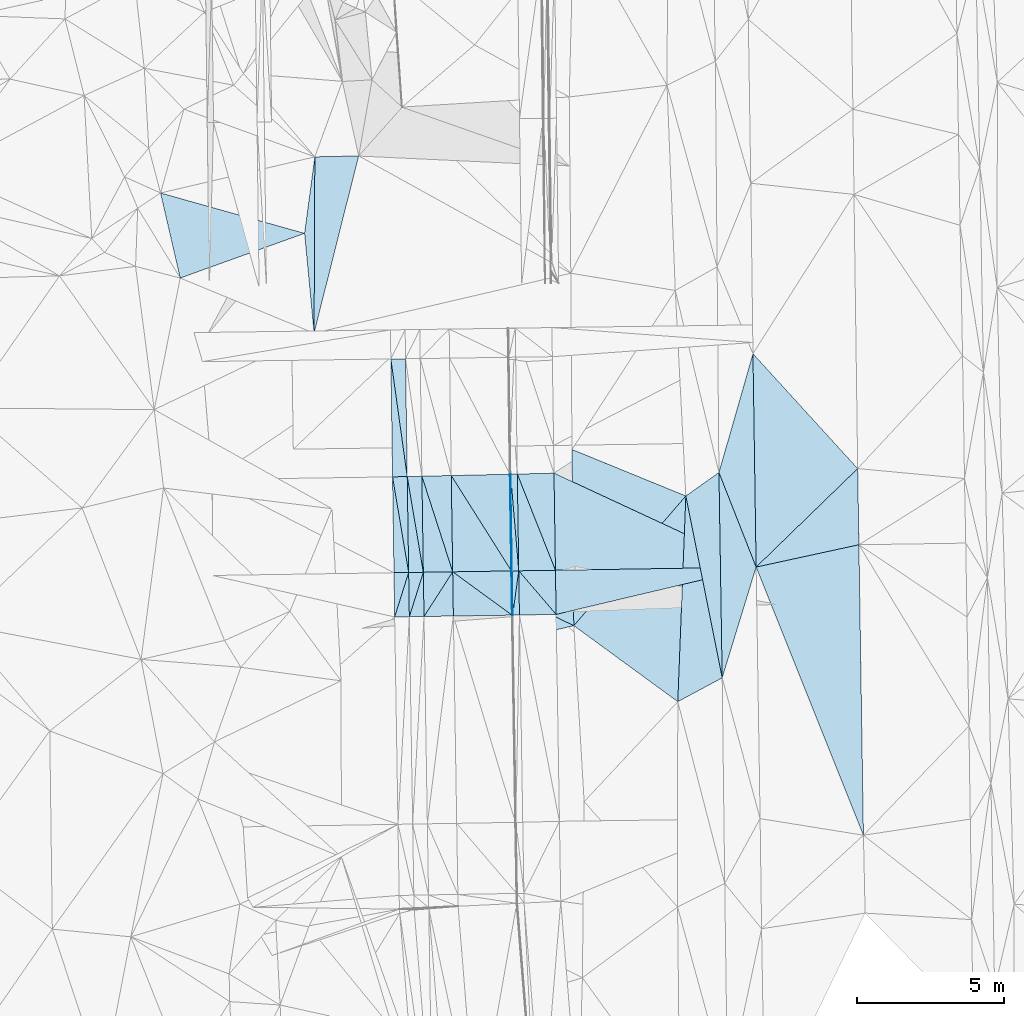
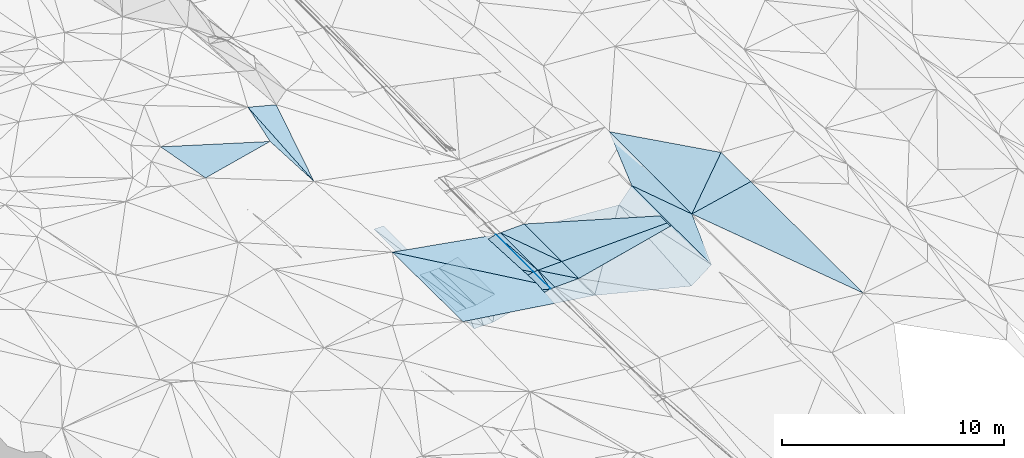
# One storey, part 7 of 275: 46 plates.
"""IFC2X3 building model written with IfcOpenShell, lengths in millimetres."""

import ifcopenshell
import ifcopenshell.guid

model = None  # the IFC model being written
_history = None  # IfcOwnerHistory: only IFC2X3 demands one
_inside = {}  # id of a spatial element -> (the spatial element, [elements in it])
_under = {}  # id of a project, library or spatial element -> (it, [spatial elements below it])
_declared = {}  # id of a project -> (the project, [libraries it declares])
_typed = {}  # id of a type object -> (the type object, [elements of that type])
_made_of = {}  # id of a material, layer set ... -> (it, [elements and type objects made of it])


def new_model(schema):
    """Start an empty IFC model of exactly this schema.

    Asked for "IFC4X3", IfcOpenShell would pick the latest addendum, in which some entities
    have other attributes; the version numbers below select the first issue.
    IFC2X3 requires an IfcOwnerHistory on every rooted entity: one is made here for all.
    """
    global model, _history
    if schema == "IFC4X3":
        model = ifcopenshell.file(schema_version=(4, 3, 0, 0))
    else:
        model = ifcopenshell.file(schema=schema)
    _inside.clear()
    _under.clear()
    _declared.clear()
    _typed.clear()
    _made_of.clear()
    _history = None
    if model.schema == "IFC2X3":
        org = make("IfcOrganization", Name="unknown")
        user = make(
            "IfcPersonAndOrganization",
            ThePerson=make("IfcPerson", FamilyName="unknown"),
            TheOrganization=org,
        )
        app = make(
            "IfcApplication",
            ApplicationDeveloper=org,
            Version="unknown",
            ApplicationFullName="unknown",
            ApplicationIdentifier="unknown",
        )
        _history = make(
            "IfcOwnerHistory",
            OwningUser=user,
            OwningApplication=app,
            ChangeAction="ADDED",
            CreationDate=0,
        )
    return model


def make(cls, **values):
    """One entity of the class cls with the attributes given. An attribute that is None is left unset."""
    return model.create_entity(
        cls, **{name: value for name, value in values.items() if value is not None}
    )


def rooted(cls, **values):
    """An entity with a GlobalId (a new one), such as an element, a storey or a relation."""
    return make(cls, GlobalId=ifcopenshell.guid.new(), OwnerHistory=_history, **values)


def si_unit(unit_type, name, prefix=None):
    """IfcSIUnit, for example si_unit("LENGTHUNIT", "METRE", prefix="MILLI")."""
    return make("IfcSIUnit", UnitType=unit_type, Prefix=prefix, Name=name)


def assignment(units):
    """IfcUnitAssignment: the units of a project."""
    return None if units is None else make("IfcUnitAssignment", Units=units)


def point(xyz):
    """IfcCartesianPoint."""
    return None if xyz is None else make("IfcCartesianPoint", Coordinates=xyz)


def direction(xyz):
    """IfcDirection."""
    return None if xyz is None else make("IfcDirection", DirectionRatios=xyz)


def frame(location, z_axis=None, x_axis=None):
    """IfcAxis2Placement3D, a coordinate frame: its origin and axes. An axis left out is left unset."""
    return make(
        "IfcAxis2Placement3D",
        Location=point(location),
        Axis=direction(z_axis),
        RefDirection=direction(x_axis),
    )


def origin_with_axes():
    """The frame at (0, 0, 0) with the z axis (0, 0, 1) and the x axis (1, 0, 0) written out."""
    return frame((0.0, 0.0, 0.0), z_axis=(0.0, 0.0, 1.0), x_axis=(1.0, 0.0, 0.0))


def place(relative_to, where):
    """IfcLocalPlacement: puts the frame where relative to a parent placement (None: the world)."""
    return make(
        "IfcLocalPlacement", PlacementRelTo=relative_to, RelativePlacement=where
    )


def context(
    kind, dimensions, precision=None, world=None, true_north=None, identifier=None
):
    """IfcGeometricRepresentationContext, for example the 3D "Model" context."""
    return make(
        "IfcGeometricRepresentationContext",
        ContextIdentifier=identifier,
        ContextType=kind,
        CoordinateSpaceDimension=dimensions,
        Precision=precision,
        WorldCoordinateSystem=world,
        TrueNorth=true_north,
    )


def subcontext(parent, identifier, kind, view, scale=None):
    """IfcGeometricRepresentationSubContext, for example "Body" below "Model"."""
    return make(
        "IfcGeometricRepresentationSubContext",
        ContextIdentifier=identifier,
        ContextType=kind,
        ParentContext=parent,
        TargetScale=scale,
        TargetView=view,
    )


def project(units=None, contexts=None):
    """IfcProject with its units and contexts."""
    return rooted(
        "IfcProject",
        Name="project",
        RepresentationContexts=contexts,
        UnitsInContext=assignment(units),
    )


def spatial(cls, under=None, at=None, **own):
    """A site, building, storey or space (cls), placed at a placement, below another one or the project."""
    s = rooted(cls, ObjectPlacement=at, **own)
    if under is not None:
        _under.setdefault(under.id(), (under, []))[1].append(s)
    return s


def polyline(points):
    """IfcPolyline through the points."""
    return make("IfcPolyline", Points=[point(p) for p in points])


def outline(outer, holes=None, kind="AREA"):
    """IfcArbitraryClosedProfileDef: a profile drawn as a closed curve; with holes, ...WithVoids."""
    if holes is None:
        return make("IfcArbitraryClosedProfileDef", ProfileType=kind, OuterCurve=outer)
    return make(
        "IfcArbitraryProfileDefWithVoids",
        ProfileType=kind,
        OuterCurve=outer,
        InnerCurves=holes,
    )


def extrude(swept, where, along, depth):
    """IfcExtrudedAreaSolid: the profile swept, set in the frame where, extruded along a direction by depth."""
    return make(
        "IfcExtrudedAreaSolid",
        SweptArea=swept,
        Position=where,
        ExtrudedDirection=direction(along),
        Depth=depth,
    )


def shape(context_of_items, identifier, shape_type, items):
    """IfcShapeRepresentation: the items that make up one representation, for example the "Body"."""
    return make(
        "IfcShapeRepresentation",
        ContextOfItems=context_of_items,
        RepresentationIdentifier=identifier,
        RepresentationType=shape_type,
        Items=items,
    )


def material(Name=None, Category=None):
    """IfcMaterial."""
    return make("IfcMaterial", Name=Name, Category=Category)


def made_of(thing, what):
    """Note that an element or type object is made of a material, layer set ...; save() writes the relation."""
    if what is not None:
        _made_of.setdefault(what.id(), (what, []))[1].append(thing)
    return thing


def type_object(cls, material=None, **own):
    """A type object (cls), such as IfcWallType, which elements share."""
    return made_of(rooted(cls, **own), material)


def element(
    cls,
    number,
    at=None,
    inside=None,
    cuts=None,
    type_object=None,
    material=None,
    context=None,
    identifier="Body",
    shape_type=None,
    held_by="IfcProductDefinitionShape",
    body=None,
    shapes=None,
    **own,
):
    """One element of the class cls, such as IfcWall. Its Tag is "e" and its number.

    at: its placement. inside: the storey or other place that contains it. cuts: it is an
    opening in that element (IfcRelVoidsElement). A single representation is given by context,
    identifier, shape_type and body (its items); several are given by shapes. held_by: the class
    of the entity that holds the representations. save() writes the other relations.
    """
    e = rooted(cls, Tag="e%d" % number, ObjectPlacement=at, **own)
    if body is not None:
        shapes = [shape(context, identifier, shape_type, body)]
    if shapes is not None:
        e.Representation = make(held_by, Representations=shapes)
    if inside is not None:
        _inside.setdefault(inside.id(), (inside, []))[1].append(e)
    if cuts is not None:
        rooted(
            "IfcRelVoidsElement", RelatingBuildingElement=cuts, RelatedOpeningElement=e
        )
    if type_object is not None:
        _typed.setdefault(type_object.id(), (type_object, []))[1].append(e)
    return made_of(e, material)


def aggregate(whole, parts):
    """IfcRelAggregates: a whole, such as a stair, and the parts it consists of."""
    return rooted("IfcRelAggregates", RelatingObject=whole, RelatedObjects=parts)


def save(model, path):
    """Write the relations noted so far, then the file.

    IfcRelAggregates (storeys below a building ...), IfcRelContainedInSpatialStructure (elements
    in a storey), IfcRelDefinesByType, IfcRelAssociatesMaterial and IfcRelDeclares: one each for
    every whole, place, type object, material and project.
    """
    for whole, parts in _under.values():
        aggregate(whole, parts)
    for where, things in _inside.values():
        rooted(
            "IfcRelContainedInSpatialStructure",
            RelatedElements=things,
            RelatingStructure=where,
        )
    for kind, things in _typed.values():
        rooted("IfcRelDefinesByType", RelatedObjects=things, RelatingType=kind)
    for what, things in _made_of.values():
        rooted("IfcRelAssociatesMaterial", RelatedObjects=things, RelatingMaterial=what)
    for by, libraries in _declared.values():
        rooted("IfcRelDeclares", RelatingContext=by, RelatedDefinitions=libraries)
    model.write(path)


model = new_model("IFC2X3")

# Units and contexts
model_context = context("Model", 3, precision=1e-05, world=origin_with_axes())
body_context = subcontext(model_context, "Body", "Model", "MODEL_VIEW")
ifc_project = project(units=[si_unit("LENGTHUNIT", "METRE", prefix="MILLI"), si_unit("AREAUNIT", "SQUARE_METRE"), si_unit("VOLUMEUNIT", "CUBIC_METRE"), si_unit("MASSUNIT", "GRAM", prefix="KILO"), si_unit("TIMEUNIT", "SECOND"), si_unit("PLANEANGLEUNIT", "RADIAN"), si_unit("SOLIDANGLEUNIT", "STERADIAN"), si_unit("THERMODYNAMICTEMPERATUREUNIT", "DEGREE_CELSIUS"), si_unit("LUMINOUSINTENSITYUNIT", "LUMEN")], contexts=[model_context])

# Site, building, storey
site_placement = place(None, origin_with_axes())
site = spatial("IfcSite", under=ifc_project, at=site_placement, CompositionType="ELEMENT")
building_placement = place(site_placement, origin_with_axes())
building = spatial("IfcBuilding", under=site, at=building_placement, Name="Undefined", CompositionType="ELEMENT")
storey_placement = place(building_placement, origin_with_axes())
storey = spatial("IfcBuildingStorey", under=building, at=storey_placement, Name="Undefined", CompositionType="ELEMENT", Elevation=0.0)

# Plates
ifc_material = material()
plate_type_1 = type_object("IfcPlateType", PredefinedType="NOTDEFINED")
plate_1_placement = place(storey_placement, frame((-93450.7812218761, -8468.57718550333, 40779.4992792065), z_axis=(0.0230198140299747, 0.0245295763712498, -0.999434033863703), x_axis=(-0.999610784874334, -0.0151943470408303, -0.0233968070668108)))
element("IfcPlate", 1, at=plate_1_placement, inside=storey, type_object=plate_type_1, material=ifc_material, Name="00_PR", context=body_context, shape_type="SweptSolid", body=[
    extrude(outline(polyline([(0.0, 0.0), (1250.34155273438, -4.55656845588237e-09), (1247.57287597656, 3297.16064453125), (0.0, 0.0)])), frame((-8.85201319254618e-08, 2.18876761149539e-07, -0.5000001331573), z_axis=(0.0, 0.0, 1.0), x_axis=(1.0, 0.0, 0.0)), (0.0, 0.0, 1.0), 1.0),
])
plate_2_placement = place(storey_placement, frame((-94700.6360550644, -8487.57886800392, 40750.2452057346), z_axis=(0.0231314602308719, 0.0174105789306933, -0.999580815786741), x_axis=(0.999610784874308, 0.0151943470417717, 0.0233968070673051)))
element("IfcPlate", 2, at=plate_2_placement, inside=storey, type_object=plate_type_1, material=ifc_material, Name="00_PR", context=body_context, shape_type="SweptSolid", body=[
    extrude(outline(polyline([(0.0, 0.0), (1250.34155273438, -4.55656845588237e-09), (1249.92895507813, 1504.56494140625), (0.0, 0.0)])), frame((-8.85201319254618e-08, 2.18876761149539e-07, -0.5000001331573), z_axis=(0.0, 0.0, 1.0), x_axis=(1.0, 0.0, 0.0)), (0.0, 0.0, 1.0), 1.0),
])
plate_type_2 = type_object("IfcPlateType", PredefinedType="NOTDEFINED")
plate_3_placement = place(storey_placement, frame((-94950.5941300159, -8491.37860899973, 40737.7456896094), z_axis=(0.0496701681121903, 0.0175022377578883, -0.998612310195089), x_axis=(0.998637023954934, 0.0151772910496966, 0.04993740304446)))
element("IfcPlate", 3, at=plate_3_placement, inside=storey, type_object=plate_type_2, material=ifc_material, Name="00_PR", context=body_context, shape_type="SweptSolid", body=[
    extrude(outline(polyline([(0.0, 0.0), (20.0250701904297, 1.0550138540566e-10), (18.9549674987793, 1506.44421386719), (0.0, 0.0)])), frame((-8.85201319254618e-08, 2.18876761149539e-07, -0.5000001331573), z_axis=(0.0, 0.0, 1.0), x_axis=(1.0, 0.0, 0.0)), (0.0, 0.0, 1.0), 1.0),
])
plate_4_placement = place(storey_placement, frame((-94999.7617032373, -5197.4115990819, 40817.4547658491), z_axis=(0.04956751671171, 0.024901228217985, -0.998460309737082), x_axis=(0.998485170887548, 0.0226700710453335, 0.0501341340452102)))
element("IfcPlate", 4, at=plate_4_placement, inside=storey, type_object=plate_type_2, material=ifc_material, Name="00_PR", context=body_context, shape_type="SweptSolid", body=[
    extrude(outline(polyline([(0.0, 0.0), (20.0262756347656, -1.20962795335799e-10), (-9.55297374725342, 3295.31176757813), (0.0, 0.0)])), frame((-8.85201319254618e-08, 2.18876761149539e-07, -0.5000001331573), z_axis=(0.0, 0.0, 1.0), x_axis=(1.0, 0.0, 0.0)), (0.0, 0.0, 1.0), 1.0),
])
plate_5_placement = place(storey_placement, frame((-94930.5964119533, -8491.07098352095, 40738.7457654583), z_axis=(0.049550166065277, 0.0249008846785979, -0.998461179508311), x_axis=(-0.998637023954719, -0.0151772910485015, -0.0499374030491363)))
element("IfcPlate", 5, at=plate_5_placement, inside=storey, type_object=plate_type_2, material=ifc_material, Name="00_PR", context=body_context, shape_type="SweptSolid", body=[
    extrude(outline(polyline([(0.0, 0.0), (20.0250701904297, 1.0550138540566e-10), (15.1516771316528, 3295.29077148438), (0.0, 0.0)])), frame((-8.85201319254618e-08, 2.18876761149539e-07, -0.5000001331573), z_axis=(0.0, 0.0, 1.0), x_axis=(1.0, 0.0, 0.0)), (0.0, 0.0, 1.0), 1.0),
])
plate_6_placement = place(storey_placement, frame((-94907.5163262495, -9997.13083329152, 40713.4976898034), z_axis=(0.0496659495565469, 0.0175021200130953, -0.998612522077354), x_axis=(-0.998632888221544, -0.0154461280523027, -0.0499376780646519)))
element("IfcPlate", 6, at=plate_6_placement, inside=storey, type_object=plate_type_2, material=ifc_material, Name="00_PR", context=body_context, shape_type="SweptSolid", body=[
    extrude(outline(polyline([(0.0, 0.0), (20.0249881744385, 1.60071067512035e-10), (18.5499820709229, 1506.44921875), (0.0, 0.0)])), frame((-8.85201319254618e-08, 2.18876761149539e-07, -0.5000001331573), z_axis=(0.0, 0.0, 1.0), x_axis=(1.0, 0.0, 0.0)), (0.0, 0.0, 1.0), 1.0),
])
plate_type_3 = type_object("IfcPlateType", PredefinedType="NOTDEFINED")
plate_7_placement = place(storey_placement, frame((-87771.7231313729, -12134.0917304585, 40839.5001567121), z_axis=(0.0152421728001892, 0.0218217227554366, -0.999645681521365), x_axis=(-0.0158134836603822, 0.999642043248423, 0.0215805260510793)))
element("IfcPlate", 7, at=plate_7_placement, inside=storey, type_object=plate_type_3, material=ifc_material, Name="00", context=body_context, shape_type="SweptSolid", body=[
    extrude(outline(polyline([(0.0, 0.0), (6997.048828125, 5.86442183703184e-09), (3756.13623046875, 1215.55981445313), (0.0, 0.0)])), frame((-8.85201319254618e-08, 2.18876761149539e-07, -0.5000001331573), z_axis=(0.0, 0.0, 1.0), x_axis=(1.0, 0.0, 0.0)), (0.0, 0.0, 1.0), 1.0),
])
plate_type_4 = type_object("IfcPlateType", PredefinedType="NOTDEFINED")
plate_8_placement = place(storey_placement, frame((-99056.4221337363, -1271.52598590732, 40163.8081410827), z_axis=(-0.000338214305154468, 0.0241722870342655, -0.999707750370386), x_axis=(0.999902128808213, 0.0139904540599465, 6.75791380713796e-11)))
element("IfcPlate", 8, at=plate_8_placement, inside=storey, type_object=plate_type_4, material=ifc_material, Name="00_PR", context=body_context, shape_type="SweptSolid", body=[
    extrude(outline(polyline([(0.0, 0.0), (499.999664306641, 2.92175172944553e-09), (501.333099365234, 4013.79077148438), (0.0, 0.0)])), frame((-8.85201319254618e-08, 2.18876761149539e-07, -0.5000001331573), z_axis=(0.0, 0.0, 1.0), x_axis=(1.0, 0.0, 0.0)), (0.0, 0.0, 1.0), 1.0),
])
plate_9_placement = place(storey_placement, frame((-98450.21511066, -8544.56883995214, 39987.7451408191), z_axis=(-0.000367404302933235, 0.0241699317748655, -0.999707797014746), x_axis=(-0.999884486551127, -0.0151991300537017, -7.36617294118191e-11)))
element("IfcPlate", 9, at=plate_9_placement, inside=storey, type_object=plate_type_4, material=ifc_material, Name="00_PR", context=body_context, shape_type="SweptSolid", body=[
    extrude(outline(polyline([(0.0, 0.0), (500.000457763672, -2.06000549951568e-09), (499.112701416016, 3265.416015625), (0.0, 0.0)])), frame((-8.85201319254618e-08, 2.18876761149539e-07, -0.5000001331573), z_axis=(0.0, 0.0, 1.0), x_axis=(1.0, 0.0, 0.0)), (0.0, 0.0, 1.0), 1.0),
])
plate_10_placement = place(storey_placement, frame((-98450.2150540166, -8544.57255150277, 39987.7450649553), z_axis=(-0.000254566875137674, 0.0167468698658155, -0.999859728934716), x_axis=(-0.300252680970975, -0.953727209111064, -0.0158977410647986)))
element("IfcPlate", 10, at=plate_10_placement, inside=storey, type_object=plate_type_4, material=ifc_material, Name="00_PR", context=body_context, shape_type="SweptSolid", body=[
    extrude(outline(polyline([(0.0, 0.0), (1588.15026855469, 2.13913153856993e-09), (157.357055664063, 474.593719482422), (0.0, 0.0)])), frame((-8.85201319254618e-08, 2.18876761149539e-07, -0.5000001331573), z_axis=(0.0, 0.0, 1.0), x_axis=(1.0, 0.0, 0.0)), (0.0, 0.0, 1.0), 1.0),
])
plate_11_placement = place(storey_placement, frame((-98927.0614148892, -10059.2346175942, 39962.4970649613), z_axis=(-0.000258762544877712, 0.0167481903598455, -0.999859705739568), x_axis=(0.300252680970031, 0.953727209111382, 0.0158977410635525)))
element("IfcPlate", 11, at=plate_11_placement, inside=storey, type_object=plate_type_4, material=ifc_material, Name="00_PR", context=body_context, shape_type="SweptSolid", body=[
    extrude(outline(polyline([(0.0, 0.0), (1588.15026855469, 2.13913153856993e-09), (157.47509765625, 474.553833007813), (0.0, 0.0)])), frame((-8.85201319254618e-08, 2.18876761149539e-07, -0.5000001331573), z_axis=(0.0, 0.0, 1.0), x_axis=(1.0, 0.0, 0.0)), (0.0, 0.0, 1.0), 1.0),
])
plate_12_placement = place(storey_placement, frame((-97950.2729334346, -8536.97058377578, 39987.7451409691), z_axis=(-0.000367372230858189, 0.0241719854889157, -0.999707747371784), x_axis=(-0.999884526343414, -0.0151965120671327, -6.01430760253441e-11)))
element("IfcPlate", 12, at=plate_12_placement, inside=storey, type_object=plate_type_4, material=ifc_material, Name="00_PR", context=body_context, shape_type="SweptSolid", body=[
    extrude(outline(polyline([(0.0, 0.0), (499.999908447266, 1.81171344593167e-09), (499.119293212891, 3269.15112304688), (0.0, 0.0)])), frame((-8.85201319254618e-08, 2.18876761149539e-07, -0.5000001331573), z_axis=(0.0, 0.0, 1.0), x_axis=(1.0, 0.0, 0.0)), (0.0, 0.0, 1.0), 1.0),
])
plate_13_placement = place(storey_placement, frame((-97950.2728779856, -8536.97429570815, 39987.7450650108), z_axis=(-0.000254544849183806, 0.016748254203229, -0.999859705752794), x_axis=(-0.300276582035642, -0.953719664321499, -0.0158989360486513)))
element("IfcPlate", 13, at=plate_13_placement, inside=storey, type_object=plate_type_4, material=ifc_material, Name="00_PR", context=body_context, shape_type="SweptSolid", body=[
    extrude(outline(polyline([(0.0, 0.0), (1588.03076171875, -2.29920260608196e-09), (157.367538452148, 474.589691162109), (0.0, 0.0)])), frame((-8.85201319254618e-08, 2.18876761149539e-07, -0.5000001331573), z_axis=(0.0, 0.0, 1.0), x_axis=(1.0, 0.0, 0.0)), (0.0, 0.0, 1.0), 1.0),
])
plate_14_placement = place(storey_placement, frame((-98427.1213250181, -10051.5104335745, 39962.4970652688), z_axis=(-0.000258796770664899, 0.0167495925185601, -0.99985968224281), x_axis=(0.300276582035562, 0.953719664321541, 0.0158989360476345)))
element("IfcPlate", 14, at=plate_14_placement, inside=storey, type_object=plate_type_4, material=ifc_material, Name="00_PR", context=body_context, shape_type="SweptSolid", body=[
    extrude(outline(polyline([(0.0, 0.0), (1588.03076171875, -2.29920260608196e-09), (157.487640380859, 474.550659179688), (0.0, 0.0)])), frame((-8.85201319254618e-08, 2.18876761149539e-07, -0.5000001331573), z_axis=(0.0, 0.0, 1.0), x_axis=(1.0, 0.0, 0.0)), (0.0, 0.0, 1.0), 1.0),
])
plate_type_5 = type_object("IfcPlateType", PredefinedType="NOTDEFINED")
plate_15_placement = place(storey_placement, frame((-94979.7657640739, -5196.95761697948, 40818.4587655052), z_axis=(0.0495651562844053, 0.0249022382401159, -0.998460401725144), x_axis=(0.998486179408631, 0.0226327480523193, 0.0501309110784482)))
element("IfcPlate", 15, at=plate_15_placement, inside=storey, type_object=plate_type_5, material=ifc_material, Name="00_PR", context=body_context, shape_type="SweptSolid", body=[
    extrude(outline(polyline([(0.0, 0.0), (230.297027587891, 6.19365891907364e-10), (200.825057983398, 3297.03002929688), (0.0, 0.0)])), frame((-8.85201319254618e-08, 2.18876761149539e-07, -0.5000001331573), z_axis=(0.0, 0.0, 1.0), x_axis=(1.0, 0.0, 0.0)), (0.0, 0.0, 1.0), 1.0),
])
plate_16_placement = place(storey_placement, frame((-94700.6228431099, -8487.57512287118, 40750.2457656175), z_axis=(0.049550166065277, 0.0249008846785979, -0.998461179508311), x_axis=(-0.998636967147769, -0.015180423044963, -0.0499375870670704)))
element("IfcPlate", 16, at=plate_16_placement, inside=storey, type_object=plate_type_5, material=ifc_material, Name="00_PR", context=body_context, shape_type="SweptSolid", body=[
    extrude(outline(polyline([(0.0, 0.0), (230.287460327148, -1.53249857248738e-09), (225.403091430664, 3295.44091796875), (0.0, 0.0)])), frame((-8.85201319254618e-08, 2.18876761149539e-07, -0.5000001331573), z_axis=(0.0, 0.0, 1.0), x_axis=(1.0, 0.0, 0.0)), (0.0, 0.0, 1.0), 1.0),
])
plate_17_placement = place(storey_placement, frame((-94700.6227832982, -8487.57882225324, 40750.245690061), z_axis=(0.0496701681121903, 0.0175022377578883, -0.998612310195089), x_axis=(-0.135747370914359, -0.990450050715051, -0.0241111660521285)))
element("IfcPlate", 17, at=plate_17_placement, inside=storey, type_object=plate_type_5, material=ifc_material, Name="00_PR", context=body_context, shape_type="SweptSolid", body=[
    extrude(outline(polyline([(0.0, 0.0), (1524.10717773438, -1.62981450557709e-09), (34.9580612182617, 227.618637084961), (0.0, 0.0)])), frame((-8.85201319254618e-08, 2.18876761149539e-07, -0.5000001331573), z_axis=(0.0, 0.0, 1.0), x_axis=(1.0, 0.0, 0.0)), (0.0, 0.0, 1.0), 1.0),
])
plate_18_placement = place(storey_placement, frame((-94907.5163262495, -9997.13083329152, 40713.4976898034), z_axis=(0.0496659495565469, 0.0175021200130953, -0.998612522077354), x_axis=(0.135747370914063, 0.990450050715106, 0.0241111660515318)))
element("IfcPlate", 18, at=plate_18_placement, inside=storey, type_object=plate_type_5, material=ifc_material, Name="00_PR", context=body_context, shape_type="SweptSolid", body=[
    extrude(outline(polyline([(0.0, 0.0), (1524.10717773438, -1.62981450557709e-09), (35.0138549804688, 227.61003112793), (0.0, 0.0)])), frame((-8.85201319254618e-08, 2.18876761149539e-07, -0.5000001331573), z_axis=(0.0, 0.0, 1.0), x_axis=(1.0, 0.0, 0.0)), (0.0, 0.0, 1.0), 1.0),
])
plate_type_6 = type_object("IfcPlateType", PredefinedType="NOTDEFINED")
plate_19_placement = place(storey_placement, frame((-94927.417633018, -9997.4389079976, 40712.5119885618), z_axis=(0.242224243020781, 0.0199682938119007, -0.970014785111676), x_axis=(-0.970026725874199, -0.0149872710412928, -0.242535632014178)))
element("IfcPlate", 19, at=plate_19_placement, inside=storey, type_object=plate_type_6, material=ifc_material, Name="00_PR", context=body_context, shape_type="SweptSolid", body=[
    extrude(outline(polyline([(0.0, 0.0), (2061.552734375, -7.5924617704004e-09), (2055.24609375, 1506.93725585938), (0.0, 0.0)])), frame((-8.85201319254618e-08, 2.18876761149539e-07, -0.5000001331573), z_axis=(0.0, 0.0, 1.0), x_axis=(1.0, 0.0, 0.0)), (0.0, 0.0, 1.0), 1.0),
])
plate_20_placement = place(storey_placement, frame((-94927.417633018, -9997.4389079976, 40712.5119885618), z_axis=(0.242227817760632, 0.0199736721832795, -0.970013781717784), x_axis=(-0.793738514048808, 0.579030762988164, -0.186286196023577)))
element("IfcPlate", 20, at=plate_20_placement, inside=storey, type_object=plate_type_6, material=ifc_material, Name="00_PR", context=body_context, shape_type="SweptSolid", body=[
    extrude(outline(polyline([(0.0, 0.0), (2548.5087890625, -4.72937244921923e-10), (885.672241210938, 1218.59594726563), (0.0, 0.0)])), frame((-8.85201319254618e-08, 2.18876761149539e-07, -0.5000001331573), z_axis=(0.0, 0.0, 1.0), x_axis=(1.0, 0.0, 0.0)), (0.0, 0.0, 1.0), 1.0),
])
plate_21_placement = place(storey_placement, frame((-86615.853583552, -8360.48424320706, 40939.500170584), z_axis=(0.0163338552628318, 0.0222505651779545, -0.99961898617499), x_axis=(-0.365900130501853, 0.930537480488905, 0.0147340389604216)))
element("IfcPlate", 21, at=plate_21_placement, inside=storey, type_object=plate_type_6, material=ifc_material, Name="00", context=body_context, shape_type="SweptSolid", body=[
    extrude(outline(polyline([(0.0, 0.0), (3461.37280273438, 4.36557456851006e-10), (6803.98828125, 2559.89086914063), (0.0, 0.0)])), frame((-8.85201319254618e-08, 2.18876761149539e-07, -0.5000001331573), z_axis=(0.0, 0.0, 1.0), x_axis=(1.0, 0.0, 0.0)), (0.0, 0.0, 1.0), 1.0),
])
plate_type_7 = type_object("IfcPlateType", PredefinedType="NOTDEFINED")
plate_22_placement = place(storey_placement, frame((-98498.9997673481, -5276.73717851929, 40066.7761409371), z_axis=(-0.00035397631738695, 0.0241700946038804, -0.999707797922776), x_axis=(-0.99974308997372, -0.0226653130598122, -0.000193994069030219)))
element("IfcPlate", 22, at=plate_22_placement, inside=storey, type_object=plate_type_7, material=ifc_material, Name="00_PR", context=body_context, shape_type="SweptSolid", body=[
    extrude(outline(polyline([(0.0, 0.0), (500.015838623047, 1.89629645319656e-09), (466.480987548828, 4017.99047851563), (0.0, 0.0)])), frame((-8.85201319254618e-08, 2.18876761149539e-07, -0.5000001331573), z_axis=(0.0, 0.0, 1.0), x_axis=(1.0, 0.0, 0.0)), (0.0, 0.0, 1.0), 1.0),
])
plate_type_8 = type_object("IfcPlateType", PredefinedType="NOTDEFINED")
plate_23_placement = place(storey_placement, frame((-98998.8871378138, -5288.07019260027, 40066.6791407993), z_axis=(-0.00035402371759246, 0.0241721850526879, -0.999707747362691), x_axis=(0.999743089973718, 0.022665313059869, 0.000193994071489403)))
element("IfcPlate", 23, at=plate_23_placement, inside=storey, type_object=plate_type_8, material=ifc_material, Name="00_PR", context=body_context, shape_type="SweptSolid", body=[
    extrude(outline(polyline([(0.0, 0.0), (500.015838623047, 1.89629645319656e-09), (474.706207275391, 3269.05322265625), (0.0, 0.0)])), frame((-8.85201319254618e-08, 2.18876761149539e-07, -0.5000001331573), z_axis=(0.0, 0.0, 1.0), x_axis=(1.0, 0.0, 0.0)), (0.0, 0.0, 1.0), 1.0),
])
plate_24_placement = place(storey_placement, frame((-98498.9997673481, -5276.73717851929, 40066.7761409371), z_axis=(-0.000354025400745904, 0.0241742311776893, -0.999707697886229), x_axis=(0.999743131890963, 0.0226634640589801, 0.000193994061412583)))
element("IfcPlate", 24, at=plate_24_placement, inside=storey, type_object=plate_type_8, material=ifc_material, Name="00_PR", context=body_context, shape_type="SweptSolid", body=[
    extrude(outline(polyline([(0.0, 0.0), (500.016204833984, -1.46019374369644e-09), (474.682373046875, 3272.78857421875), (0.0, 0.0)])), frame((-8.85201319254618e-08, 2.18876761149539e-07, -0.5000001331573), z_axis=(0.0, 0.0, 1.0), x_axis=(1.0, 0.0, 0.0)), (0.0, 0.0, 1.0), 1.0),
])
plate_type_9 = type_object("IfcPlateType", PredefinedType="NOTDEFINED")
plate_25_placement = place(storey_placement, frame((-97998.9907702252, -5265.40362548332, 40066.8880583716), z_axis=(0.242096529945446, 0.0270755625192678, -0.969874313559566), x_axis=(0.969851070317032, 0.0219867310538938, 0.242704522130246)))
element("IfcPlate", 25, at=plate_25_placement, inside=storey, type_object=plate_type_9, material=ifc_material, Name="00_PR", context=body_context, shape_type="SweptSolid", body=[
    extrude(outline(polyline([(0.0, 0.0), (1030.85424804688, -1.11162989924196e-09), (986.980163574219, 3280.06298828125), (0.0, 0.0)])), frame((-8.85201319254618e-08, 2.18876761149539e-07, -0.5000001331573), z_axis=(0.0, 0.0, 1.0), x_axis=(1.0, 0.0, 0.0)), (0.0, 0.0, 1.0), 1.0),
])
plate_type_10 = type_object("IfcPlateType", PredefinedType="NOTDEFINED")
plate_26_placement = place(storey_placement, frame((-96950.26724922, -8521.77039225416, 40237.7600570764), z_axis=(0.24208578451909, 0.0270719563769047, -0.969877096395055), x_axis=(-0.970030439638978, -0.0147449450410086, -0.242535631958583)))
element("IfcPlate", 26, at=plate_26_placement, inside=storey, type_object=plate_type_10, material=ifc_material, Name="00_PR", context=body_context, shape_type="SweptSolid", body=[
    extrude(outline(polyline([(0.0, 0.0), (1030.7763671875, 4.52564563602209e-09), (1010.72131347656, 3272.8251953125), (0.0, 0.0)])), frame((-8.85201319254618e-08, 2.18876761149539e-07, -0.5000001331573), z_axis=(0.0, 0.0, 1.0), x_axis=(1.0, 0.0, 0.0)), (0.0, 0.0, 1.0), 1.0),
])
plate_type_11 = type_object("IfcPlateType", PredefinedType="NOTDEFINED")
plate_27_placement = place(storey_placement, frame((-96950.2671772251, -8521.77394539002, 40237.7599889095), z_axis=(0.242228007552131, 0.0199657174092067, -0.970013898088919), x_axis=(-0.533965462931209, -0.832010329998061, -0.150464930044106)))
element("IfcPlate", 27, at=plate_27_placement, inside=storey, type_object=plate_type_11, material=ifc_material, Name="00_PR", context=body_context, shape_type="SweptSolid", body=[
    extrude(outline(polyline([(0.0, 0.0), (1829.31665039063, -6.31553120911121e-09), (584.16552734375, 849.264709472656), (0.0, 0.0)])), frame((-8.85201319254618e-08, 2.18876761149539e-07, -0.5000001331573), z_axis=(0.0, 0.0, 1.0), x_axis=(1.0, 0.0, 0.0)), (0.0, 0.0, 1.0), 1.0),
])
plate_28_placement = place(storey_placement, frame((-97927.0590826007, -10043.7842795758, 39962.5119883367), z_axis=(0.242224243020781, 0.0199682938119007, -0.970014785111676), x_axis=(0.533965462932028, 0.832010329997851, 0.150464930042362)))
element("IfcPlate", 28, at=plate_28_placement, inside=storey, type_object=plate_type_11, material=ifc_material, Name="00_PR", context=body_context, shape_type="SweptSolid", body=[
    extrude(outline(polyline([(0.0, 0.0), (1829.31665039063, -6.31553120911121e-09), (584.370849609375, 849.122924804688), (0.0, 0.0)])), frame((-8.85201319254618e-08, 2.18876761149539e-07, -0.5000001331573), z_axis=(0.0, 0.0, 1.0), x_axis=(1.0, 0.0, 0.0)), (0.0, 0.0, 1.0), 1.0),
])
plate_type_12 = type_object("IfcPlateType", PredefinedType="NOTDEFINED")
plate_29_placement = place(storey_placement, frame((-94950.4979228879, -8491.37382231194, 40737.7600572923), z_axis=(0.242085677555394, 0.0270754664294681, -0.969877025112036), x_axis=(-0.970030439638978, -0.0147449450410086, -0.242535631958583)))
element("IfcPlate", 29, at=plate_29_placement, inside=storey, type_object=plate_type_12, material=ifc_material, Name="00_PR", context=body_context, shape_type="SweptSolid", body=[
    extrude(outline(polyline([(0.0, 0.0), (2061.55322265625, 1.61162461154163e-09), (2041.44873046875, 3280.29467773438), (0.0, 0.0)])), frame((-8.85201319254618e-08, 2.18876761149539e-07, -0.5000001331573), z_axis=(0.0, 0.0, 1.0), x_axis=(1.0, 0.0, 0.0)), (0.0, 0.0, 1.0), 1.0),
])
plate_type_13 = type_object("IfcPlateType", PredefinedType="NOTDEFINED")
plate_30_placement = place(storey_placement, frame((-94950.4979228879, -8491.37382231194, 40737.7600572923), z_axis=(0.242097271106054, 0.0270831808816183, -0.969873915844908), x_axis=(-0.53025349703462, 0.840818736974285, -0.108881037998017)))
element("IfcPlate", 30, at=plate_30_placement, inside=storey, type_object=plate_type_13, material=ifc_material, Name="00_PR", context=body_context, shape_type="SweptSolid", body=[
    extrude(outline(polyline([(0.0, 0.0), (3863.6572265625, 2.5902409106493e-09), (2787.0185546875, 1758.26416015625), (0.0, 0.0)])), frame((-8.85201319254618e-08, 2.18876761149539e-07, -0.5000001331573), z_axis=(0.0, 0.0, 1.0), x_axis=(1.0, 0.0, 0.0)), (0.0, 0.0, 1.0), 1.0),
])
plate_type_14 = type_object("IfcPlateType", PredefinedType="NOTDEFINED")
plate_31_placement = place(storey_placement, frame((-94749.831008693, -5191.74568203336, 40830.0032673246), z_axis=(0.0222697243847474, 0.0242325887213946, -0.999458273776193), x_axis=(0.999439182485159, 0.0244668330308229, 0.0228625150593625)))
element("IfcPlate", 31, at=plate_31_placement, inside=storey, type_object=plate_type_14, material=ifc_material, Name="00_PR", context=body_context, shape_type="SweptSolid", body=[
    extrude(outline(polyline([(0.0, 0.0), (1250.38745117188, -8.2577571447473e-09), (1216.99255371094, 3308.56982421875), (0.0, 0.0)])), frame((-8.85201319254618e-08, 2.18876761149539e-07, -0.5000001331573), z_axis=(0.0, 0.0, 1.0), x_axis=(1.0, 0.0, 0.0)), (0.0, 0.0, 1.0), 1.0),
])
plate_type_15 = type_object("IfcPlateType", PredefinedType="NOTDEFINED")
plate_32_placement = place(storey_placement, frame((-93427.7295935309, -9972.75037292889, 40753.8331991408), z_axis=(0.0227775299015942, 0.0171072008646982, -0.999594181560776), x_axis=(-0.999595226999751, -0.0166582280445499, -0.0230626450723134)))
element("IfcPlate", 32, at=plate_32_placement, inside=storey, type_object=plate_type_15, material=ifc_material, Name="00_PR", context=body_context, shape_type="SweptSolid", body=[
    extrude(outline(polyline([(0.0, 0.0), (1250.33361816406, 1.16688170237467e-09), (1247.73376464844, 1506.38586425781), (0.0, 0.0)])), frame((-8.85201319254618e-08, 2.18876761149539e-07, -0.5000001331573), z_axis=(0.0, 0.0, 1.0), x_axis=(1.0, 0.0, 0.0)), (0.0, 0.0, 1.0), 1.0),
])
plate_type_16 = type_object("IfcPlateType", PredefinedType="NOTDEFINED")
plate_33_placement = place(storey_placement, frame((-93427.7294157949, -9972.7502211839, 40753.8332057792), z_axis=(0.0231241531575841, 0.0174104703732879, -0.999580986745009), x_axis=(-0.0153212040498861, 0.999737095300053, 0.017058751052595)))
element("IfcPlate", 33, at=plate_33_placement, inside=storey, type_object=plate_type_16, material=ifc_material, Name="00_PR", context=body_context, shape_type="SweptSolid", body=[
    extrude(outline(polyline([(0.0, 0.0), (1504.56506347656, 5.23868948221207e-10), (1510.64074707031, 6837.6552734375), (0.0, 0.0)])), frame((-8.85201319254618e-08, 2.18876761149539e-07, -0.5000001331573), z_axis=(0.0, 0.0, 1.0), x_axis=(1.0, 0.0, 0.0)), (0.0, 0.0, 1.0), 1.0),
])
plate_type_17 = type_object("IfcPlateType", PredefinedType="NOTDEFINED")
plate_34_placement = place(storey_placement, frame((-93450.7812201142, -8468.57732880676, 40779.4992760137), z_axis=(0.0230128198866037, 0.0242432698064693, -0.999441180855561), x_axis=(-0.0149190550509108, 0.999602939300628, 0.0239036720596093)))
element("IfcPlate", 34, at=plate_34_placement, inside=storey, type_object=plate_type_17, material=ifc_material, Name="00_PR", context=body_context, shape_type="SweptSolid", body=[
    extrude(outline(polyline([(0.0, 0.0), (3308.73852539063, -5.82076609134674e-10), (9.90502548217773, 6837.65087890625), (0.0, 0.0)])), frame((-8.85201319254618e-08, 2.18876761149539e-07, -0.5000001331573), z_axis=(0.0, 0.0, 1.0), x_axis=(1.0, 0.0, 0.0)), (0.0, 0.0, 1.0), 1.0),
])
plate_type_18 = type_object("IfcPlateType", PredefinedType="NOTDEFINED")
plate_35_placement = place(storey_placement, frame((-101671.366187928, -392.605461080082, 43166.5191648846), z_axis=(-0.265036902738616, 0.0707974746131822, -0.961635667898772), x_axis=(0.0042351733904276, 0.997376725645068, 0.0722615419699578)))
element("IfcPlate", 35, at=plate_35_placement, inside=storey, type_object=plate_type_18, material=ifc_material, Name="00", context=body_context, shape_type="SweptSolid", body=[
    extrude(outline(polyline([(0.0, 0.0), (6019.7998046875, 2.47382558882236e-09), (6029.99951171875, 1548.27221679688), (0.0, 0.0)])), frame((-8.85201319254618e-08, 2.18876761149539e-07, -0.5000001331573), z_axis=(0.0, 0.0, 1.0), x_axis=(1.0, 0.0, 0.0)), (0.0, 0.0, 1.0), 1.0),
])
plate_type_19 = type_object("IfcPlateType", PredefinedType="NOTDEFINED")
plate_36_placement = place(storey_placement, frame((-101995.010115492, 3005.67419771159, 43419.5033152514), z_axis=(-0.108238357879894, 0.0401685765235102, -0.993313114452608), x_axis=(-0.937344096532543, -0.336974106477416, 0.0885126898209401)))
element("IfcPlate", 36, at=plate_36_placement, inside=storey, type_object=plate_type_19, material=ifc_material, Name="00", context=body_context, shape_type="SweptSolid", body=[
    extrude(outline(polyline([(0.0, 0.0), (4519.1259765625, 4.22005541622639e-09), (4186.318359375, 2960.63159179688), (0.0, 0.0)])), frame((-8.85201319254618e-08, 2.18876761149539e-07, -0.5000001331573), z_axis=(0.0, 0.0, 1.0), x_axis=(1.0, 0.0, 0.0)), (0.0, 0.0, 1.0), 1.0),
])
plate_type_20 = type_object("IfcPlateType", PredefinedType="NOTDEFINED")
plate_37_placement = place(storey_placement, frame((-101645.748722705, 5611.40328813658, 43601.5013823986), z_axis=(-0.020017406298217, 0.0723322671176464, -0.997179696232687), x_axis=(-0.00423517337791783, -0.997376725639402, -0.072261542048896)))
element("IfcPlate", 37, at=plate_37_placement, inside=storey, type_object=plate_type_20, material=ifc_material, Name="00", context=body_context, shape_type="SweptSolid", body=[
    extrude(outline(polyline([(0.0, 0.0), (6019.7998046875, 2.47382558882236e-09), (2613.50805664063, 338.219421386719), (0.0, 0.0)])), frame((-8.85201319254618e-08, 2.18876761149539e-07, -0.5000001331573), z_axis=(0.0, 0.0, 1.0), x_axis=(1.0, 0.0, 0.0)), (0.0, 0.0, 1.0), 1.0),
])
plate_type_21 = type_object("IfcPlateType", PredefinedType="NOTDEFINED")
plate_38_placement = place(storey_placement, frame((-89283.9404283743, -12944.8297219747, 40686.514245073), z_axis=(0.237009044854132, 0.00749194861124265, -0.971478555277129), x_axis=(-0.792712901488519, 0.579580082685103, -0.188926397224906)))
element("IfcPlate", 38, at=plate_38_placement, inside=storey, type_object=plate_type_21, material=ifc_material, Name="00", context=body_context, shape_type="SweptSolid", body=[
    extrude(outline(polyline([(0.0, 0.0), (4467.34814453125, 2.50583980232477e-08), (3820.2412109375, 5880.78759765625), (0.0, 0.0)])), frame((-8.85201319254618e-08, 2.18876761149539e-07, -0.5000001331573), z_axis=(0.0, 0.0, 1.0), x_axis=(1.0, 0.0, 0.0)), (0.0, 0.0, 1.0), 1.0),
])
plate_type_22 = type_object("IfcPlateType", PredefinedType="NOTDEFINED")
plate_39_placement = place(storey_placement, frame((-86615.852327437, -8360.48422477914, 40939.5001939263), z_axis=(0.018841350682667, 0.0222866944928042, -0.999574062665212), x_axis=(-0.0147978026738095, 0.99964824338832, 0.0220094190444417)))
element("IfcPlate", 39, at=plate_39_placement, inside=storey, type_object=plate_type_22, material=ifc_material, Name="00", context=body_context, shape_type="SweptSolid", body=[
    extrude(outline(polyline([(0.0, 0.0), (7269.61474609375, -2.48837750405073e-09), (3305.74609375, 3508.6953125), (0.0, 0.0)])), frame((-8.85201319254618e-08, 2.18876761149539e-07, -0.5000001331573), z_axis=(0.0, 0.0, 1.0), x_axis=(1.0, 0.0, 0.0)), (0.0, 0.0, 1.0), 1.0),
])
plate_type_23 = type_object("IfcPlateType", PredefinedType="NOTDEFINED")
plate_40_placement = place(storey_placement, frame((-86615.8510247787, -8360.48560358757, 40939.5001904911), z_axis=(0.0214500527334771, 0.0195298772345196, -0.999579151009532), x_axis=(0.976894001343009, 0.212244182739189, 0.0251100982359554)))
element("IfcPlate", 40, at=plate_40_placement, inside=storey, type_object=plate_type_23, material=ifc_material, Name="00", context=body_context, shape_type="SweptSolid", body=[
    extrude(outline(polyline([(0.0, 0.0), (3584.21533203125, -1.00208126241341e-08), (1629.39428710938, 9700.849609375), (0.0, 0.0)])), frame((-8.85201319254618e-08, 2.18876761149539e-07, -0.5000001331573), z_axis=(0.0, 0.0, 1.0), x_axis=(1.0, 0.0, 0.0)), (0.0, 0.0, 1.0), 1.0),
])
plate_type_24 = type_object("IfcPlateType", PredefinedType="NOTDEFINED")
plate_41_placement = place(storey_placement, frame((-87771.6840201302, -12134.0958787651, 40839.5022219437), z_axis=(0.0934625002320456, 0.0135313051764428, -0.995530845745423), x_axis=(-0.877862576209484, -0.470605690719284, -0.0888120552260475)))
element("IfcPlate", 41, at=plate_41_placement, inside=storey, type_object=plate_type_24, material=ifc_material, Name="00", context=body_context, shape_type="SweptSolid", body=[
    extrude(outline(polyline([(0.0, 0.0), (1722.73913574219, -1.12158886622638e-08), (-1826.17150878906, 6048.39990234375), (0.0, 0.0)])), frame((-8.85201319254618e-08, 2.18876761149539e-07, -0.5000001331573), z_axis=(0.0, 0.0, 1.0), x_axis=(1.0, 0.0, 0.0)), (0.0, 0.0, 1.0), 1.0),
])
plate_type_25 = type_object("IfcPlateType", PredefinedType="NOTDEFINED")
plate_42_placement = place(storey_placement, frame((-92825.262876894, -10355.6456133271, 39842.514756003), z_axis=(0.241232164641248, 0.00362131902887218, -0.97046067864236), x_axis=(-0.0103189065365302, 0.999946078474318, 0.0011663240213614)))
element("IfcPlate", 42, at=plate_42_placement, inside=storey, type_object=plate_type_25, material=ifc_material, Name="00", context=body_context, shape_type="SweptSolid", body=[
    extrude(outline(polyline([(0.0, 0.0), (6001.76171875, 1.65891833603382e-09), (4378.60302734375, 3978.72412109375), (0.0, 0.0)])), frame((-8.85201319254618e-08, 2.18876761149539e-07, -0.5000001331573), z_axis=(0.0, 0.0, 1.0), x_axis=(1.0, 0.0, 0.0)), (0.0, 0.0, 1.0), 1.0),
])
plate_type_26 = type_object("IfcPlateType", PredefinedType="NOTDEFINED")
plate_43_placement = place(storey_placement, frame((-83157.0804838938, -5005.45854121166, 41079.5001978598), z_axis=(0.0214310810510141, 0.0196170419366966, -0.999577851110477), x_axis=(0.0164261375071903, -0.999679433733127, -0.0192668569727998)))
element("IfcPlate", 43, at=plate_43_placement, inside=storey, type_object=plate_type_26, material=ifc_material, Name="00", context=body_context, shape_type="SweptSolid", body=[
    extrude(outline(polyline([(0.0, 0.0), (2595.13012695313, 2.91038304567337e-11), (3299.83471679688, 3514.25537109375), (0.0, 0.0)])), frame((-8.85201319254618e-08, 2.18876761149539e-07, -0.5000001331573), z_axis=(0.0, 0.0, 1.0), x_axis=(1.0, 0.0, 0.0)), (0.0, 0.0, 1.0), 1.0),
])
plate_type_27 = type_object("IfcPlateType", PredefinedType="NOTDEFINED")
plate_44_placement = place(storey_placement, frame((-89009.4901561542, -5938.54470945251, 40807.5053269115), z_axis=(0.143864433505732, 0.0236333991110281, -0.989315160713983), x_axis=(0.808764303960105, 0.573288343657436, 0.131304134232094)))
element("IfcPlate", 44, at=plate_44_placement, inside=storey, type_object=plate_type_27, material=ifc_material, Name="00", context=body_context, shape_type="SweptSolid", body=[
    extrude(outline(polyline([(0.0, 0.0), (1393.71081542969, 5.36238076165318e-09), (-2546.51879882813, 5782.15234375), (0.0, 0.0)])), frame((-8.85201319254618e-08, 2.18876761149539e-07, -0.5000001331573), z_axis=(0.0, 0.0, 1.0), x_axis=(1.0, 0.0, 0.0)), (0.0, 0.0, 1.0), 1.0),
])
plate_type_28 = type_object("IfcPlateType", PredefinedType="NOTDEFINED")
plate_45_placement = place(storey_placement, frame((-100754.118361179, -12233.8862747532, 42317.5246918561), z_axis=(-0.307271917660168, 0.0444775521413182, -0.950581777635654), x_axis=(-0.0519188615564086, 0.996635826853018, 0.0634149859866516)))
element("IfcPlate", 45, at=plate_45_placement, inside=storey, type_object=plate_type_28, material=ifc_material, Name="00", context=body_context, shape_type="SweptSolid", body=[
    extrude(outline(polyline([(0.0, 0.0), (5881.890625, 6.54836185276508e-10), (1303.34729003906, 8415.2939453125), (0.0, 0.0)])), frame((-8.85201319254618e-08, 2.18876761149539e-07, -0.5000001331573), z_axis=(0.0, 0.0, 1.0), x_axis=(1.0, 0.0, 0.0)), (0.0, 0.0, 1.0), 1.0),
])
plate_type_29 = type_object("IfcPlateType", PredefinedType="NOTDEFINED")
plate_46_placement = place(storey_placement, frame((-92887.479052104, -4354.2103591475, 39849.5276240595), z_axis=(-0.327868135315768, -0.00228151319803813, -0.944720742093709), x_axis=(0.0103189065573673, -0.999946078474127, -0.00116632400137051)))
element("IfcPlate", 46, at=plate_46_placement, inside=storey, type_object=plate_type_29, material=ifc_material, Name="00", context=body_context, shape_type="SweptSolid", body=[
    extrude(outline(polyline([(0.0, 0.0), (6001.76171875, 1.65891833603382e-09), (1929.84777832031, 8671.779296875), (0.0, 0.0)])), frame((-8.85201319254618e-08, 2.18876761149539e-07, -0.5000001331573), z_axis=(0.0, 0.0, 1.0), x_axis=(1.0, 0.0, 0.0)), (0.0, 0.0, 1.0), 1.0),
])

save(model, "model.ifc")
